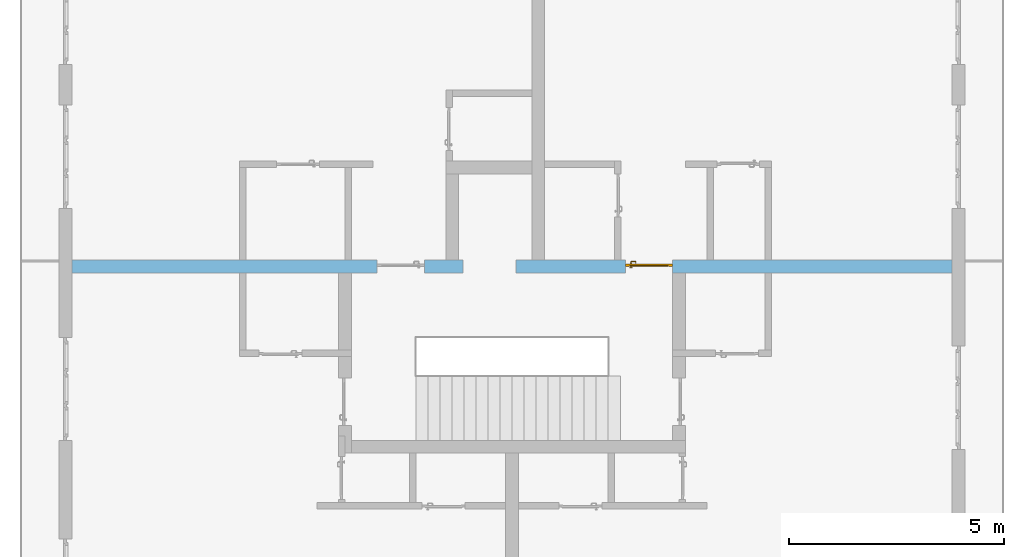
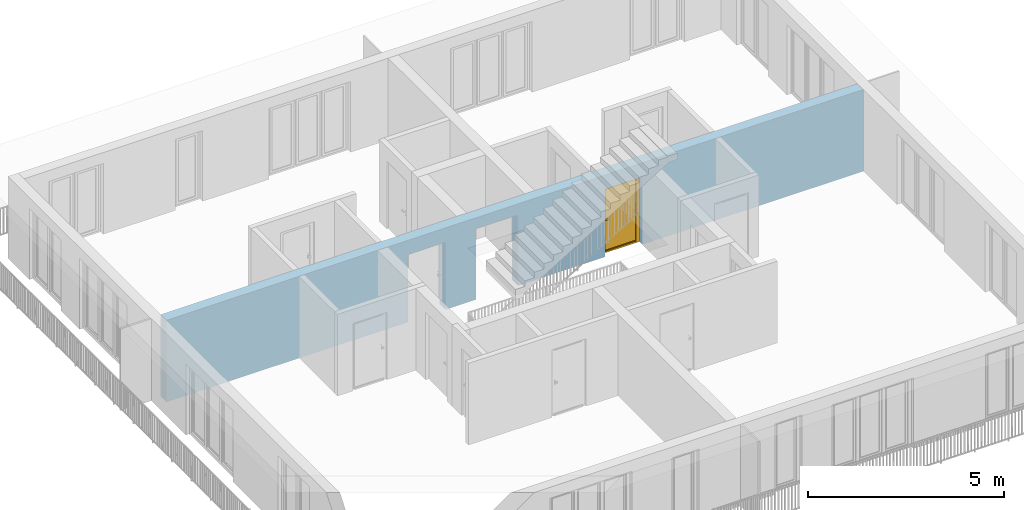
# One storey, part 14 of 48: 1 door, 3 openings, plus 1 element that does not belong to this part.
"""IFC4 building model written with IfcOpenShell, lengths in metres."""

from ifc_helpers import new_model, entity, si_unit, converted_unit, derived_unit, direction, frame, origin_with_axes, place, context, subcontext, project, spatial, polygons, source, transform, mapped, material, type_object, element, fill, save


model = new_model("IFC4")

# Units and contexts
model_context = context("Model", 3, precision=1e-05, world=origin_with_axes(), true_north=direction((0.0, 1.0)))
body_context = subcontext(model_context, "Body", "Model", "MODEL_VIEW")
ifc_project = project(units=[si_unit("LENGTHUNIT", "METRE"), si_unit("AREAUNIT", "SQUARE_METRE"), si_unit("VOLUMEUNIT", "CUBIC_METRE"), converted_unit("PLANEANGLEUNIT", "DEGREE", entity("IfcPlaneAngleMeasure", 0.0174532925199), si_unit("PLANEANGLEUNIT", "RADIAN"), dimensions=[0, 0, 0, 0, 0, 0, 0]), converted_unit("TIMEUNIT", "Year", entity("IfcTimeMeasure", 31556926.0), si_unit("TIMEUNIT", "SECOND"), dimensions=[0, 0, 1, 0, 0, 0, 0]), si_unit("MASSUNIT", "GRAM", prefix="KILO"), si_unit("THERMODYNAMICTEMPERATUREUNIT", "DEGREE_CELSIUS"), si_unit("LUMINOUSINTENSITYUNIT", "LUMEN"), si_unit("ENERGYUNIT", "JOULE", prefix="MEGA"), derived_unit("THERMALCONDUCTANCEUNIT", [(si_unit("POWERUNIT", "WATT"), 1), (si_unit("LENGTHUNIT", "METRE"), -1), (si_unit("THERMODYNAMICTEMPERATUREUNIT", "KELVIN"), -1)]), derived_unit("SPECIFICHEATCAPACITYUNIT", [(si_unit("ENERGYUNIT", "JOULE"), 1), (si_unit("MASSUNIT", "GRAM", prefix="KILO"), -1), (si_unit("THERMODYNAMICTEMPERATUREUNIT", "KELVIN"), -1)]), derived_unit("MASSDENSITYUNIT", [(si_unit("MASSUNIT", "GRAM", prefix="KILO"), 1), (si_unit("VOLUMEUNIT", "CUBIC_METRE"), -1)])], contexts=[model_context])

# Site, building, storey
site_placement = place(None, origin_with_axes())
site = spatial("IfcSite", under=ifc_project, at=site_placement, CompositionType="ELEMENT")
building_placement = place(site_placement, origin_with_axes())
building = spatial("IfcBuilding", under=site, at=building_placement, CompositionType="ELEMENT")
storey_placement = place(building_placement, frame((0.0, 0.0, 3.4), z_axis=(0.0, 0.0, 1.0), x_axis=(1.0, 0.0, 0.0)))
storey = spatial("IfcBuildingStorey", under=building, at=storey_placement, Name="1. Geschoss", CompositionType="ELEMENT", Elevation=3.4)

# Wall, openings, door
ifc_material = material()
wall_type = type_object("IfcWallType", Name="300", PredefinedType="NOTDEFINED")
wall_placement = place(storey_placement, frame((-11.7421993804, 1.37118776896, 0.0), z_axis=(0.0, 0.0, 1.0), x_axis=(1.0, 0.0, 0.0)))
wall = element("IfcWall", 1, at=wall_placement, inside=storey, type_object=wall_type, material=ifc_material, Name="Wand-001", PredefinedType="NOTDEFINED", context=body_context, shape_type="Tessellation", body=[
    polygons([(9.4, 0.3, 2.2), (9.4, 0.3, 0.0), (8.5, 0.3, 0.0), (8.5, 0.3, 2.1), (7.4, 0.3, 2.1), (7.4, 0.3, 0.0), (0.3, 0.3, 0.0), (0.3, 0.3, 2.54), (20.78, 0.3, 2.54), (20.78, 0.3, 0.0), (14.28, 0.3, 0.0), (14.28, 0.3, 2.1), (13.18, 0.3, 2.1), (13.18, 0.3, 0.0), (10.63, 0.3, 0.0), (10.63, 0.3, 2.2), (9.4, 0.0, 2.2), (9.4, 0.0, 0.0), (8.5, 0.0, 0.0), (8.5, 0.0, 2.1), (7.4, 0.0, 2.1), (7.4, 0.0, 0.0), (0.3, 0.0, 0.0), (0.3, 0.0, 2.54), (20.78, 0.0, 2.54), (20.78, 0.0, 0.0), (14.28, 0.0, 0.0), (14.28, 0.0, 2.1), (13.18, 0.0, 2.1), (13.18, 0.0, 0.0), (10.63, 0.0, 0.0), (10.63, 0.0, 2.2)], [[[1, 2, 3, 4, 5, 6, 7, 8, 9, 10, 11, 12, 13, 14, 15, 16]], [[2, 1, 17, 18]], [[2, 18, 19, 3]], [[20, 4, 3, 19]], [[21, 5, 4, 20]], [[22, 6, 5, 21]], [[7, 6, 22, 23]], [[24, 8, 7, 23]], [[25, 9, 8, 24]], [[9, 25, 26, 10]], [[10, 26, 27, 11]], [[11, 27, 28, 12]], [[12, 28, 29, 13]], [[13, 29, 30, 14]], [[31, 15, 14, 30]], [[16, 15, 31, 32]], [[1, 16, 32, 17]], [[32, 31, 30, 29, 28, 27, 26, 25, 24, 23, 22, 21, 20, 19, 18, 17]]], closed=True),
])
opening_1_placement = place(wall_placement, frame((7.95, 0.0, 0.0), z_axis=(0.0, 0.0, 1.0), x_axis=(1.0, 0.0, 0.0)))
element("IfcOpeningElement", 2, at=opening_1_placement, cuts=wall, context=body_context, identifier="Reference", shape_type="Tessellation", body=[
    polygons([(0.55, 0.15, 0.0), (0.55, 0.15, 2.1), (0.55, -0.001, 2.1), (0.55, -0.001, 0.0), (0.55, 0.301, 0.0), (0.55, 0.301, 2.1), (-0.55, 0.15, 2.1), (-0.55, -0.001, 2.1), (-0.55, 0.301, 2.1), (-0.55, -0.001, 0.0), (-0.55, 0.15, 0.0), (-0.55, 0.301, 0.0)], [[[1, 2, 3, 4]], [[2, 1, 5, 6]], [[7, 8, 3, 2, 6, 9]], [[8, 10, 4, 3]], [[1, 4, 10, 11, 12, 5]], [[6, 5, 12, 9]], [[7, 11, 10, 8]], [[11, 7, 9, 12]]], closed=True),
])
opening_2_placement = place(wall_placement, frame((13.73, 0.0, 0.0), z_axis=(0.0, 0.0, 1.0), x_axis=(1.0, 0.0, 0.0)))
opening_2 = element("IfcOpeningElement", 3, at=opening_2_placement, cuts=wall, context=body_context, identifier="Reference", shape_type="Tessellation", body=[
    polygons([(0.55, 0.15, 0.0), (0.55, 0.15, 2.1), (0.55, -0.001, 2.1), (0.55, -0.001, 0.0), (0.55, 0.301, 0.0), (0.55, 0.301, 2.1), (-0.55, 0.15, 2.1), (-0.55, -0.001, 2.1), (-0.55, 0.301, 2.1), (-0.55, -0.001, 0.0), (-0.55, 0.15, 0.0), (-0.55, 0.301, 0.0)], [[[1, 2, 3, 4]], [[2, 1, 5, 6]], [[7, 8, 3, 2, 6, 9]], [[8, 10, 4, 3]], [[1, 4, 10, 11, 12, 5]], [[6, 5, 12, 9]], [[7, 11, 10, 8]], [[11, 7, 9, 12]]], closed=True),
])
opening_3_placement = place(wall_placement, frame((10.015, 0.0, 0.0), z_axis=(0.0, 0.0, 1.0), x_axis=(1.0, 0.0, 0.0)))
element("IfcOpeningElement", 4, at=opening_3_placement, cuts=wall, context=body_context, identifier="Reference", shape_type="Tessellation", body=[
    polygons([(-0.615, -0.001, 2.2), (-0.615, -0.001, 0.0), (0.615, -0.001, 0.0), (0.615, -0.001, 2.2), (-0.615, 0.301, 2.2), (-0.615, 0.301, 0.0), (0.615, 0.301, 0.0), (0.615, 0.301, 2.2)], [[[1, 2, 3, 4]], [[5, 6, 2, 1]], [[6, 7, 3, 2]], [[7, 8, 4, 3]], [[8, 5, 1, 4]], [[7, 6, 5, 8]]], closed=True),
])
door_type = type_object("IfcDoorType", Name="Eingang 01 1-Fl 26", OperationType="SINGLE_SWING_RIGHT", PredefinedType="DOOR")
shared_shape = source(origin_with_axes(), body_context, "Body", "Tessellation", [
    polygons([(0.55, -0.05, 0.0), (0.55, -0.03, 0.0), (0.55, -0.03, 2.1), (0.55, -0.05, 2.1), (0.45, -0.05, 0.0), (0.45, -0.03, 0.0), (0.45, -0.03, 2.0), (0.1301, -0.03, 2.0), (0.0001, -0.03, 2.0), (-0.45, -0.03, 2.0), (-0.45, -0.03, 0.0), (-0.55, -0.03, 0.0), (-0.55, -0.03, 2.1), (-0.55, -0.05, 2.1), (-0.55, -0.05, 0.0), (-0.45, -0.05, 0.0), (-0.45, -0.05, 2.0), (0.0001, -0.05, 2.0), (0.1301, -0.05, 2.0), (0.45, -0.05, 2.0)], [[[1, 2, 3, 4]], [[5, 6, 2, 1]], [[2, 6, 7, 8, 9, 10, 11, 12, 13, 3]], [[4, 3, 13, 14]], [[1, 4, 14, 15, 16, 17, 18, 19, 20, 5]], [[20, 7, 6, 5]], [[19, 8, 7, 20]], [[18, 9, 8, 19]], [[17, 10, 9, 18]], [[16, 11, 10, 17]], [[15, 12, 11, 16]], [[14, 13, 12, 15]]], closed=True),
    polygons([(0.55, -0.03, 0.0), (0.55, 0.0, 0.0), (0.55, 0.0, 2.1), (0.55, -0.03, 2.1), (0.48, -0.03, 0.0), (0.48, 0.0, 0.0), (0.48, 0.0, 2.03), (0.1001, 0.0, 2.03), (0.0301, 0.0, 2.03), (-0.48, 0.0, 2.03), (-0.48, 0.0, 0.0), (-0.55, 0.0, 0.0), (-0.55, 0.0, 2.1), (-0.55, -0.03, 2.1), (-0.55, -0.03, 0.0), (-0.48, -0.03, 0.0), (-0.48, -0.03, 2.03), (0.0301, -0.03, 2.03), (0.1001, -0.03, 2.03), (0.48, -0.03, 2.03)], [[[1, 2, 3, 4]], [[5, 6, 2, 1]], [[2, 6, 7, 8, 9, 10, 11, 12, 13, 3]], [[4, 3, 13, 14]], [[1, 4, 14, 15, 16, 17, 18, 19, 20, 5]], [[20, 7, 6, 5]], [[19, 8, 7, 20]], [[18, 9, 8, 19]], [[17, 10, 9, 18]], [[16, 11, 10, 17]], [[15, 12, 11, 16]], [[14, 13, 12, 15]]], closed=True),
    polygons([(0.48, 0.01, 0.0), (-0.48, 0.01, 0.0), (-0.48, 0.01, 2.03), (0.48, 0.01, 2.03), (0.48, -0.03, 0.0), (-0.48, -0.03, 0.0), (-0.48, -0.03, 2.03), (0.48, -0.03, 2.03)], [[[1, 2, 3, 4]], [[2, 1, 5, 6]], [[3, 2, 6, 7]], [[4, 3, 7, 8]], [[1, 4, 8, 5]], [[6, 5, 8, 7]]], closed=True),
    polygons([(0.445, -0.05, 0.0), (0.445, -0.05, 0.05), (-0.445, -0.05, 0.05), (-0.445, -0.05, 0.0), (0.445, -0.03, 0.0), (0.445, -0.03, 0.07), (0.445, -0.035, 0.07), (-0.445, -0.035, 0.07), (-0.445, -0.03, 0.07), (-0.445, -0.03, 0.0)], [[[1, 2, 3, 4]], [[1, 5, 6, 7, 2]], [[2, 7, 8, 3]], [[4, 3, 8, 9, 10]], [[5, 1, 4, 10]], [[6, 5, 10, 9]], [[7, 6, 9, 8]]], closed=True),
    polygons([(-0.4335, 0.02, 1.0733826859), (-0.4335, 0.0199, 1.0733826859), (-0.42, 0.0199, 1.077), (-0.42, 0.02, 1.077), (-0.443382685902, 0.02, 1.0635), (-0.443382685902, 0.0199, 1.0635), (-0.4335, 0.0101, 1.0733826859), (-0.42, 0.0101, 1.077), (-0.4065, 0.0199, 1.0733826859), (-0.4065, 0.02, 1.0733826859), (-0.396617314098, 0.02, 1.0635), (-0.393, 0.02, 1.05), (-0.396617314098, 0.02, 1.0365), (-0.4065, 0.02, 1.0266173141), (-0.42, 0.02, 1.023), (-0.4335, 0.02, 1.0266173141), (-0.443382685902, 0.02, 1.0365), (-0.447, 0.02, 1.05), (-0.447, 0.0199, 1.05), (-0.443382685902, 0.0101, 1.0635), (-0.4335, 0.01, 1.0733826859), (-0.42, 0.01, 1.077), (-0.4065, 0.0101, 1.0733826859), (-0.396617314098, 0.0199, 1.0635), (-0.393, 0.0199, 1.05), (-0.396617314098, 0.0199, 1.0365), (-0.4065, 0.0199, 1.0266173141), (-0.42, 0.0199, 1.023), (-0.4335, 0.0199, 1.0266173141), (-0.443382685902, 0.0199, 1.0365), (-0.447, 0.0101, 1.05), (-0.443382685902, 0.01, 1.0635), (-0.447, 0.01, 1.05), (-0.443382685902, 0.01, 1.0365), (-0.4335, 0.01, 1.0266173141), (-0.42, 0.01, 1.023), (-0.4065, 0.01, 1.0266173141), (-0.396617314098, 0.01, 1.0365), (-0.393, 0.01, 1.05), (-0.396617314098, 0.01, 1.0635), (-0.4065, 0.01, 1.0733826859), (-0.396617314098, 0.0101, 1.0635), (-0.393, 0.0101, 1.05), (-0.396617314098, 0.0101, 1.0365), (-0.4065, 0.0101, 1.0266173141), (-0.42, 0.0101, 1.023), (-0.4335, 0.0101, 1.0266173141), (-0.443382685902, 0.0101, 1.0365)], [[[1, 2, 3, 4]], [[5, 6, 2, 1]], [[2, 7, 8, 3]], [[4, 3, 9, 10]], [[4, 10, 11, 12, 13, 14, 15, 16, 17, 18, 5, 1]], [[18, 19, 6, 5]], [[6, 20, 7, 2]], [[7, 21, 22, 8]], [[3, 8, 23, 9]], [[10, 9, 24, 11]], [[11, 24, 25, 12]], [[12, 25, 26, 13]], [[13, 26, 27, 14]], [[14, 27, 28, 15]], [[15, 28, 29, 16]], [[16, 29, 30, 17]], [[17, 30, 19, 18]], [[19, 31, 20, 6]], [[20, 32, 21, 7]], [[22, 21, 32, 33, 34, 35, 36, 37, 38, 39, 40, 41]], [[8, 22, 41, 23]], [[9, 23, 42, 24]], [[24, 42, 43, 25]], [[25, 43, 44, 26]], [[26, 44, 45, 27]], [[27, 45, 46, 28]], [[28, 46, 47, 29]], [[29, 47, 48, 30]], [[30, 48, 31, 19]], [[31, 33, 32, 20]], [[48, 34, 33, 31]], [[47, 35, 34, 48]], [[46, 36, 35, 47]], [[45, 37, 36, 46]], [[44, 38, 37, 45]], [[43, 39, 38, 44]], [[42, 40, 39, 43]], [[23, 41, 40, 42]]], closed=True),
    polygons([(-0.412532169224, 0.019, 0.959692280177), (-0.415, 0.019, 0.9544), (-0.415, 0.019, 0.952886751346), (-0.397569942042, 0.019, 0.96295), (-0.40705, 0.019, 0.972430057958), (-0.413279754556, 0.019, 0.961639806549), (-0.412532169224, 0.02, 0.959692280177), (-0.415, 0.02, 0.9544), (-0.415, 0.02, 0.952886751346), (-0.415, 0.02, 0.95), (-0.415, 0.02, 0.947113248654), (-0.415, 0.02, 0.941339745962), (-0.415, 0.02, 0.9375), (-0.415, 0.019, 0.9375), (-0.415, 0.019, 0.941339745962), (-0.415, 0.019, 0.947113248654), (-0.415, 0.019, 0.95), (-0.3941, 0.019, 0.95), (-0.397483339502, 0.019, 0.963), (-0.407, 0.019, 0.972516660498), (-0.414624817685, 0.019, 0.965143815798), (-0.42, 0.019, 0.9759), (-0.42, 0.019, 0.967425445323), (-0.414624817685, 0.02, 0.965143815798), (-0.413279754556, 0.02, 0.961639806549), (-0.40655, 0.02, 0.973296083362), (-0.396703916638, 0.02, 0.96345), (-0.3931, 0.02, 0.95), (-0.396703916638, 0.02, 0.93655), (-0.40655, 0.02, 0.926703916638), (-0.42, 0.02, 0.9231), (-0.42, 0.02, 0.9325), (-0.416464466094, 0.02, 0.933964466094), (-0.416464466094, 0.019, 0.933964466094), (-0.40705, 0.019, 0.927569942042), (-0.42, 0.019, 0.9325), (-0.42, 0.019, 0.9241), (-0.397569942042, 0.019, 0.93705), (-0.394, 0.019, 0.95), (-0.397483339502, 0.0189, 0.963), (-0.407, 0.0189, 0.972516660498), (-0.42, 0.019, 0.976), (-0.425375182315, 0.019, 0.965143815798), (-0.43295, 0.019, 0.972430057958), (-0.426720245444, 0.019, 0.961639806549), (-0.42, 0.02, 0.967425445323), (-0.42, 0.02, 0.9769), (-0.396617314098, 0.02, 0.9635), (-0.4065, 0.02, 0.973382685902), (-0.393, 0.02, 0.95), (-0.396617314098, 0.02, 0.9365), (-0.4065, 0.02, 0.926617314098), (-0.43345, 0.02, 0.926703916638), (-0.425, 0.02, 0.941339745962), (-0.425, 0.02, 0.9375), (-0.423535533906, 0.02, 0.933964466094), (-0.42, 0.02, 0.923), (-0.423535533906, 0.019, 0.933964466094), (-0.425, 0.019, 0.9375), (-0.425, 0.019, 0.941339745962), (-0.43295, 0.019, 0.927569942042), (-0.42, 0.019, 0.924), (-0.407, 0.019, 0.927483339502), (-0.397483339502, 0.019, 0.937), (-0.394, 0.0189, 0.95), (-0.397483339502, 0.0101, 0.963), (-0.407, 0.0101, 0.972516660498), (-0.42, 0.0189, 0.976), (-0.433, 0.019, 0.972516660498), (-0.425375182315, 0.02, 0.965143815798), (-0.427467830776, 0.019, 0.959692280177), (-0.442430057958, 0.019, 0.96295), (-0.425, 0.019, 0.952886751346), (-0.425, 0.019, 0.9544), (-0.427467830776, 0.02, 0.959692280177), (-0.426720245444, 0.02, 0.961639806549), (-0.43345, 0.02, 0.973296083362), (-0.42, 0.02, 0.977), (-0.396617314098, 0.0199, 0.9635), (-0.4065, 0.0199, 0.973382685902), (-0.393, 0.0199, 0.95), (-0.396617314098, 0.0199, 0.9365), (-0.4065, 0.0199, 0.926617314098), (-0.443296083362, 0.02, 0.93655), (-0.425, 0.02, 0.947113248654), (-0.425, 0.02, 0.9544), (-0.425, 0.019, 0.95), (-0.425, 0.019, 0.947113248654), (-0.425, 0.02, 0.95), (-0.425, 0.02, 0.952886751346), (-0.4335, 0.02, 0.926617314098), (-0.42, 0.0199, 0.923), (-0.442430057958, 0.019, 0.93705), (-0.433, 0.019, 0.927483339502), (-0.42, 0.0189, 0.924), (-0.407, 0.0189, 0.927483339502), (-0.397483339502, 0.0189, 0.937), (-0.394, 0.0101, 0.95), (-0.397483339502, 0.01, 0.963), (-0.407, 0.01, 0.972516660498), (-0.42, 0.0101, 0.976), (-0.433, 0.0189, 0.972516660498), (-0.442516660498, 0.019, 0.963), (-0.4459, 0.019, 0.95), (-0.443296083362, 0.02, 0.96345), (-0.4335, 0.02, 0.973382685902), (-0.42, 0.0199, 0.977), (-0.396617314098, 0.0101, 0.9635), (-0.4065, 0.0101, 0.973382685902), (-0.393, 0.0101, 0.95), (-0.396617314098, 0.0101, 0.9365), (-0.4065, 0.0101, 0.926617314098), (-0.443382685902, 0.02, 0.9365), (-0.4469, 0.02, 0.95), (-0.4335, 0.0199, 0.926617314098), (-0.42, 0.0101, 0.923), (-0.442516660498, 0.019, 0.937), (-0.433, 0.0189, 0.927483339502), (-0.42, 0.0101, 0.924), (-0.407, 0.0101, 0.927483339502), (-0.397483339502, 0.0101, 0.937), (-0.394, 0.01, 0.95), (-0.397396736961, 0.01, 0.96305), (-0.40695, 0.01, 0.972603263039), (-0.42, 0.01, 0.976), (-0.433, 0.0101, 0.972516660498), (-0.442516660498, 0.0189, 0.963), (-0.446, 0.019, 0.95), (-0.443382685902, 0.02, 0.9635), (-0.4335, 0.0199, 0.973382685902), (-0.42, 0.0101, 0.977), (-0.396617314098, 0.01, 0.9635), (-0.4065, 0.01, 0.973382685902), (-0.393, 0.01, 0.95), (-0.396617314098, 0.01, 0.9365), (-0.4065, 0.01, 0.926617314098), (-0.447, 0.02, 0.95), (-0.443382685902, 0.0199, 0.9365), (-0.4335, 0.0101, 0.926617314098), (-0.42, 0.01, 0.923), (-0.442516660498, 0.0189, 0.937), (-0.433, 0.0101, 0.927483339502), (-0.42, 0.01, 0.924), (-0.407, 0.01, 0.927483339502), (-0.397483339502, 0.01, 0.937), (-0.3939, 0.01, 0.95), (-0.396703916638, 0.01, 0.96345), (-0.40655, 0.01, 0.973296083362), (-0.42, 0.01, 0.9761), (-0.433, 0.01, 0.972516660498), (-0.442516660498, 0.0101, 0.963), (-0.446, 0.0189, 0.95), (-0.443382685902, 0.0199, 0.9635), (-0.4335, 0.0101, 0.973382685902), (-0.42, 0.01, 0.977), (-0.3931, 0.01, 0.95), (-0.396703916638, 0.01, 0.93655), (-0.40655, 0.01, 0.926703916638), (-0.447, 0.0199, 0.95), (-0.443382685902, 0.0101, 0.9365), (-0.4335, 0.01, 0.926617314098), (-0.42, 0.01, 0.9231), (-0.442516660498, 0.0101, 0.937), (-0.433, 0.01, 0.927483339502), (-0.42, 0.01, 0.9239), (-0.40695, 0.01, 0.927396736961), (-0.397396736961, 0.01, 0.93695), (-0.42, 0.01, 0.9769), (-0.43305, 0.01, 0.972603263039), (-0.442516660498, 0.01, 0.963), (-0.446, 0.0101, 0.95), (-0.443382685902, 0.0101, 0.9635), (-0.4335, 0.01, 0.973382685902), (-0.447, 0.0101, 0.95), (-0.443382685902, 0.01, 0.9365), (-0.43345, 0.01, 0.926703916638), (-0.442516660498, 0.01, 0.937), (-0.43305, 0.01, 0.927396736961), (-0.43345, 0.01, 0.973296083362), (-0.442603263039, 0.01, 0.96305), (-0.446, 0.01, 0.95), (-0.443382685902, 0.01, 0.9635), (-0.447, 0.01, 0.95), (-0.443296083362, 0.01, 0.93655), (-0.442603263039, 0.01, 0.93695), (-0.443296083362, 0.01, 0.96345), (-0.4461, 0.01, 0.95), (-0.4469, 0.01, 0.95)], [[[1, 2, 3, 4, 5, 6]], [[2, 1, 7, 8]], [[2, 8, 9, 10, 11, 12, 13, 14, 15, 16, 17, 3]], [[17, 18, 4, 3]], [[4, 19, 20, 5]], [[21, 6, 5, 22, 23]], [[1, 6, 21, 24, 25, 7]], [[7, 25, 26, 27, 9, 8]], [[9, 27, 28, 10]], [[10, 28, 29, 11]], [[11, 29, 30, 12]], [[31, 32, 33, 13, 12, 30]], [[14, 13, 33, 34]], [[35, 15, 14, 34, 36, 37]], [[15, 35, 38, 16]], [[16, 38, 18, 17]], [[18, 39, 19, 4]], [[19, 40, 41, 20]], [[5, 20, 42, 22]], [[43, 23, 22, 44, 45]], [[21, 23, 46, 24]], [[24, 46, 47, 26, 25]], [[48, 27, 26, 49]], [[50, 28, 27, 48]], [[51, 29, 28, 50]], [[52, 30, 29, 51]], [[53, 54, 55, 56, 32, 31]], [[34, 33, 32, 36]], [[57, 31, 30, 52]], [[37, 36, 58, 59, 60, 61]], [[37, 62, 63, 35]], [[35, 63, 64, 38]], [[38, 64, 39, 18]], [[39, 65, 40, 19]], [[40, 66, 67, 41]], [[20, 41, 68, 42]], [[22, 42, 69, 44]], [[23, 43, 70, 46]], [[71, 45, 44, 72, 73, 74]], [[43, 45, 71, 75, 76, 70]], [[70, 76, 77, 47, 46]], [[49, 26, 47, 78]], [[79, 48, 49, 80]], [[81, 50, 48, 79]], [[82, 51, 50, 81]], [[83, 52, 51, 82]], [[54, 53, 84, 85]], [[86, 74, 73, 87, 88, 60, 59, 55, 54, 85, 89, 90]], [[58, 56, 55, 59]], [[36, 32, 56, 58]], [[91, 53, 31, 57]], [[92, 57, 52, 83]], [[88, 93, 61, 60]], [[61, 94, 62, 37]], [[62, 95, 96, 63]], [[63, 96, 97, 64]], [[64, 97, 65, 39]], [[65, 98, 66, 40]], [[66, 99, 100, 67]], [[41, 67, 101, 68]], [[42, 68, 102, 69]], [[44, 69, 103, 72]], [[73, 72, 104, 87]], [[71, 74, 86, 75]], [[75, 86, 90, 105, 77, 76]], [[78, 47, 77, 106]], [[80, 49, 78, 107]], [[108, 79, 80, 109]], [[110, 81, 79, 108]], [[111, 82, 81, 110]], [[112, 83, 82, 111]], [[113, 84, 53, 91]], [[85, 84, 114, 89]], [[87, 104, 93, 88]], [[89, 114, 105, 90]], [[115, 91, 57, 92]], [[116, 92, 83, 112]], [[93, 117, 94, 61]], [[94, 118, 95, 62]], [[95, 119, 120, 96]], [[96, 120, 121, 97]], [[97, 121, 98, 65]], [[98, 122, 99, 66]], [[99, 123, 124, 100]], [[67, 100, 125, 101]], [[68, 101, 126, 102]], [[69, 102, 127, 103]], [[72, 103, 128, 104]], [[106, 77, 105, 129]], [[107, 78, 106, 130]], [[109, 80, 107, 131]], [[132, 108, 109, 133]], [[134, 110, 108, 132]], [[135, 111, 110, 134]], [[136, 112, 111, 135]], [[137, 114, 84, 113]], [[138, 113, 91, 115]], [[104, 128, 117, 93]], [[129, 105, 114, 137]], [[139, 115, 92, 116]], [[140, 116, 112, 136]], [[117, 141, 118, 94]], [[118, 142, 119, 95]], [[119, 143, 144, 120]], [[120, 144, 145, 121]], [[121, 145, 122, 98]], [[122, 146, 123, 99]], [[123, 147, 148, 124]], [[100, 124, 149, 125]], [[101, 125, 150, 126]], [[102, 126, 151, 127]], [[103, 127, 152, 128]], [[130, 106, 129, 153]], [[131, 107, 130, 154]], [[133, 109, 131, 155]], [[147, 132, 133, 148]], [[156, 134, 132, 147]], [[157, 135, 134, 156]], [[158, 136, 135, 157]], [[159, 137, 113, 138]], [[160, 138, 115, 139]], [[128, 152, 141, 117]], [[153, 129, 137, 159]], [[161, 139, 116, 140]], [[162, 140, 136, 158]], [[141, 163, 142, 118]], [[142, 164, 143, 119]], [[143, 165, 166, 144]], [[144, 166, 167, 145]], [[145, 167, 146, 122]], [[146, 156, 147, 123]], [[124, 148, 168, 149]], [[125, 149, 169, 150]], [[126, 150, 170, 151]], [[127, 151, 171, 152]], [[154, 130, 153, 172]], [[155, 131, 154, 173]], [[148, 133, 155, 168]], [[167, 157, 156, 146]], [[166, 158, 157, 167]], [[174, 159, 138, 160]], [[175, 160, 139, 161]], [[152, 171, 163, 141]], [[172, 153, 159, 174]], [[176, 161, 140, 162]], [[165, 162, 158, 166]], [[163, 177, 164, 142]], [[164, 178, 165, 143]], [[149, 168, 179, 169]], [[150, 169, 180, 170]], [[151, 170, 181, 171]], [[173, 154, 172, 182]], [[168, 155, 173, 179]], [[183, 174, 160, 175]], [[184, 175, 161, 176]], [[171, 181, 177, 163]], [[182, 172, 174, 183]], [[178, 176, 162, 165]], [[177, 185, 178, 164]], [[169, 179, 186, 180]], [[170, 180, 187, 181]], [[179, 173, 182, 186]], [[188, 183, 175, 184]], [[185, 184, 176, 178]], [[181, 187, 185, 177]], [[186, 182, 183, 188]], [[180, 186, 188, 187]], [[187, 188, 184, 185]]], closed=True),
    polygons([(-0.43, 0.02, 1.05), (-0.43, 0.0509849140336, 1.05), (-0.427071067812, 0.050696439392, 1.04292893219), (-0.427071067812, 0.02, 1.04292893219), (-0.427071067812, 0.02, 1.05707106781), (-0.427071067812, 0.050696439392, 1.05707106781), (-0.428277987014, 0.0596420579258, 1.05), (-0.425518993221, 0.0584992452783, 1.04292893219), (-0.42, 0.05, 1.04), (-0.42, 0.02, 1.04), (-0.42, 0.02, 1.06), (-0.42, 0.05, 1.06), (-0.425518993221, 0.0584992452783, 1.05707106781), (-0.422816199938, 0.0678161999379, 1.05), (-0.420704557509, 0.0657045575088, 1.04292893219), (-0.418858192988, 0.0557402514855, 1.04), (-0.412928932188, 0.049303560608, 1.04292893219), (-0.412928932188, 0.02, 1.04292893219), (-0.412928932188, 0.02, 1.05707106781), (-0.412928932188, 0.049303560608, 1.05707106781), (-0.418858192988, 0.0557402514855, 1.06), (-0.420704557509, 0.0657045575088, 1.05707106781), (-0.414642057926, 0.0732779870137, 1.05), (-0.413499245278, 0.0705189932208, 1.04292893219), (-0.415606601718, 0.0606066017178, 1.04), (-0.412197392755, 0.0529812576926, 1.04292893219), (-0.41, 0.0490150859664, 1.05), (-0.41, 0.02, 1.05), (-0.412197392755, 0.0529812576926, 1.05707106781), (-0.415606601718, 0.0606066017178, 1.06), (-0.413499245278, 0.0705189932208, 1.05707106781), (-0.405984914034, 0.075, 1.05), (-0.405696439392, 0.0720710678119, 1.04292893219), (-0.410740251485, 0.0638581929877, 1.04), (-0.410508645927, 0.0555086459268, 1.04292893219), (-0.409438398962, 0.0518384450452, 1.05), (-0.410508645927, 0.0555086459268, 1.05707106781), (-0.410740251485, 0.0638581929877, 1.06), (-0.405696439392, 0.0720710678119, 1.05707106781), (-0.324015085966, 0.075, 1.05), (-0.324303560608, 0.0720710678119, 1.04292893219), (-0.405, 0.065, 1.04), (-0.407981257693, 0.0571973927545, 1.04292893219), (-0.408397003498, 0.0533970034977, 1.05), (-0.407981257693, 0.0571973927545, 1.05707106781), (-0.405, 0.065, 1.06), (-0.324303560608, 0.0720710678119, 1.05707106781), (-0.315357942074, 0.0732779870137, 1.05), (-0.316500754722, 0.0705189932208, 1.04292893219), (-0.325, 0.065, 1.04), (-0.404303560608, 0.0579289321881, 1.04292893219), (-0.406838445045, 0.0544383989617, 1.05), (-0.404303560608, 0.0579289321881, 1.05707106781), (-0.325, 0.065, 1.06), (-0.316500754722, 0.0705189932208, 1.05707106781), (-0.307183800062, 0.0678161999379, 1.05), (-0.309295442491, 0.0657045575088, 1.04292893219), (-0.319259748515, 0.0638581929877, 1.04), (-0.325696439392, 0.0579289321881, 1.04292893219), (-0.404015085966, 0.055, 1.05), (-0.325696439392, 0.0579289321881, 1.05707106781), (-0.319259748515, 0.0638581929877, 1.06), (-0.309295442491, 0.0657045575088, 1.05707106781), (-0.301722012986, 0.0596420579258, 1.05), (-0.304481006779, 0.0584992452783, 1.04292893219), (-0.314393398282, 0.0606066017178, 1.04), (-0.322018742307, 0.0571973927545, 1.04292893219), (-0.325984914034, 0.055, 1.05), (-0.322018742307, 0.0571973927545, 1.05707106781), (-0.314393398282, 0.0606066017178, 1.06), (-0.304481006779, 0.0584992452783, 1.05707106781), (-0.3, 0.0509849140336, 1.05), (-0.302928932188, 0.050696439392, 1.04292893219), (-0.311141807012, 0.0557402514855, 1.04), (-0.319491354073, 0.0555086459268, 1.04292893219), (-0.323161554955, 0.0544383989617, 1.05), (-0.319491354073, 0.0555086459268, 1.05707106781), (-0.311141807012, 0.0557402514855, 1.06), (-0.302928932188, 0.050696439392, 1.05707106781), (-0.3, 0.02, 1.05), (-0.302928932188, 0.02, 1.04292893219), (-0.31, 0.05, 1.04), (-0.317802607245, 0.0529812576926, 1.04292893219), (-0.321602996502, 0.0533970034977, 1.05), (-0.317802607245, 0.0529812576926, 1.05707106781), (-0.31, 0.05, 1.06), (-0.302928932188, 0.02, 1.05707106781), (-0.31, 0.02, 1.06), (-0.317071067812, 0.02, 1.05707106781), (-0.32, 0.02, 1.05), (-0.317071067812, 0.02, 1.04292893219), (-0.31, 0.02, 1.04), (-0.317071067812, 0.049303560608, 1.04292893219), (-0.320561601038, 0.0518384450452, 1.05), (-0.317071067812, 0.049303560608, 1.05707106781), (-0.32, 0.0490150859664, 1.05)], [[[1, 2, 3, 4]], [[5, 6, 2, 1]], [[2, 7, 8, 3]], [[4, 3, 9, 10]], [[11, 12, 6, 5]], [[6, 13, 7, 2]], [[7, 14, 15, 8]], [[3, 8, 16, 9]], [[10, 9, 17, 18]], [[19, 20, 12, 11]], [[12, 21, 13, 6]], [[13, 22, 14, 7]], [[14, 23, 24, 15]], [[8, 15, 25, 16]], [[9, 16, 26, 17]], [[18, 17, 27, 28]], [[28, 27, 20, 19]], [[20, 29, 21, 12]], [[21, 30, 22, 13]], [[22, 31, 23, 14]], [[23, 32, 33, 24]], [[15, 24, 34, 25]], [[16, 25, 35, 26]], [[17, 26, 36, 27]], [[27, 36, 29, 20]], [[29, 37, 30, 21]], [[30, 38, 31, 22]], [[31, 39, 32, 23]], [[32, 40, 41, 33]], [[24, 33, 42, 34]], [[25, 34, 43, 35]], [[26, 35, 44, 36]], [[36, 44, 37, 29]], [[37, 45, 38, 30]], [[38, 46, 39, 31]], [[39, 47, 40, 32]], [[40, 48, 49, 41]], [[33, 41, 50, 42]], [[34, 42, 51, 43]], [[35, 43, 52, 44]], [[44, 52, 45, 37]], [[45, 53, 46, 38]], [[46, 54, 47, 39]], [[47, 55, 48, 40]], [[48, 56, 57, 49]], [[41, 49, 58, 50]], [[42, 50, 59, 51]], [[43, 51, 60, 52]], [[52, 60, 53, 45]], [[53, 61, 54, 46]], [[54, 62, 55, 47]], [[55, 63, 56, 48]], [[56, 64, 65, 57]], [[49, 57, 66, 58]], [[50, 58, 67, 59]], [[51, 59, 68, 60]], [[60, 68, 61, 53]], [[61, 69, 62, 54]], [[62, 70, 63, 55]], [[63, 71, 64, 56]], [[64, 72, 73, 65]], [[57, 65, 74, 66]], [[58, 66, 75, 67]], [[59, 67, 76, 68]], [[68, 76, 69, 61]], [[69, 77, 70, 62]], [[70, 78, 71, 63]], [[71, 79, 72, 64]], [[72, 80, 81, 73]], [[65, 73, 82, 74]], [[66, 74, 83, 75]], [[67, 75, 84, 76]], [[76, 84, 77, 69]], [[77, 85, 78, 70]], [[78, 86, 79, 71]], [[79, 87, 80, 72]], [[80, 87, 88, 89, 90, 91, 92, 81]], [[73, 81, 92, 82]], [[74, 82, 93, 83]], [[75, 83, 94, 84]], [[84, 94, 85, 77]], [[85, 95, 86, 78]], [[86, 88, 87, 79]], [[95, 89, 88, 86]], [[96, 90, 89, 95]], [[93, 91, 90, 96]], [[82, 92, 91, 93]], [[83, 93, 96, 94]], [[94, 96, 95, 85]]], closed=False),
    polygons([(-0.414696699141, -0.035, 1.04469669914), (-0.42, -0.035, 1.0425), (-0.425303300859, -0.035, 1.04469669914), (-0.4275, -0.035, 1.05), (-0.425303300859, -0.035, 1.05530330086), (-0.42, -0.035, 1.0575), (-0.414696699141, -0.035, 1.05530330086), (-0.4125, -0.035, 1.05), (-0.414696699141, -0.075, 1.04469669914), (-0.42, -0.075, 1.0425), (-0.425303300859, -0.075, 1.04469669914), (-0.4275, -0.075, 1.05), (-0.425303300859, -0.075, 1.05530330086), (-0.42, -0.075, 1.0575), (-0.414696699141, -0.075, 1.05530330086), (-0.4125, -0.075, 1.05)], [[[1, 2, 3, 4, 5, 6, 7, 8]], [[2, 1, 9, 10]], [[3, 2, 10, 11]], [[4, 3, 11, 12]], [[5, 4, 12, 13]], [[6, 5, 13, 14]], [[7, 6, 14, 15]], [[8, 7, 15, 16]], [[1, 8, 16, 9]], [[9, 16, 15, 14, 13, 12, 11, 10]]], closed=True),
    polygons([(-0.445, -0.03, 0.975), (-0.443096988313, -0.03, 0.965432914191), (-0.443096988313, -0.035, 0.965432914191), (-0.445, -0.035, 0.975), (-0.445, -0.03, 1.1), (-0.443096988313, -0.03, 1.10956708581), (-0.43767766953, -0.03, 1.11767766953), (-0.429567085809, -0.03, 1.12309698831), (-0.42, -0.03, 1.125), (-0.410432914191, -0.03, 1.12309698831), (-0.40232233047, -0.03, 1.11767766953), (-0.396903011687, -0.03, 1.10956708581), (-0.395, -0.03, 1.1), (-0.395, -0.03, 0.975), (-0.396903011687, -0.03, 0.965432914191), (-0.40232233047, -0.03, 0.95732233047), (-0.410432914191, -0.03, 0.951903011687), (-0.42, -0.03, 0.95), (-0.429567085809, -0.03, 0.951903011687), (-0.43767766953, -0.03, 0.95732233047), (-0.43767766953, -0.035, 0.95732233047), (-0.429567085809, -0.035, 0.951903011687), (-0.42, -0.035, 0.95), (-0.410432914191, -0.035, 0.951903011687), (-0.40232233047, -0.035, 0.95732233047), (-0.396903011687, -0.035, 0.965432914191), (-0.395, -0.035, 0.975), (-0.395, -0.035, 1.1), (-0.396903011687, -0.035, 1.10956708581), (-0.40232233047, -0.035, 1.11767766953), (-0.410432914191, -0.035, 1.12309698831), (-0.42, -0.035, 1.125), (-0.429567085809, -0.035, 1.12309698831), (-0.43767766953, -0.035, 1.11767766953), (-0.443096988313, -0.035, 1.10956708581), (-0.445, -0.035, 1.1)], [[[1, 2, 3, 4]], [[1, 5, 6, 7, 8, 9, 10, 11, 12, 13, 14, 15, 16, 17, 18, 19, 20, 2]], [[2, 20, 21, 3]], [[4, 3, 21, 22, 23, 24, 25, 26, 27, 28, 29, 30, 31, 32, 33, 34, 35, 36]], [[5, 1, 4, 36]], [[6, 5, 36, 35]], [[7, 6, 35, 34]], [[8, 7, 34, 33]], [[9, 8, 33, 32]], [[10, 9, 32, 31]], [[11, 10, 31, 30]], [[12, 11, 30, 29]], [[13, 12, 29, 28]], [[14, 13, 28, 27]], [[15, 14, 27, 26]], [[16, 15, 26, 25]], [[17, 16, 25, 24]], [[18, 17, 24, 23]], [[19, 18, 23, 22]], [[20, 19, 22, 21]]], closed=True),
    polygons([(-0.44, -0.075, 1.08), (-0.445, -0.075, 1.07866025404), (-0.445, -0.09, 1.07866025404), (-0.44, -0.09, 1.08), (-0.4, -0.075, 1.08), (-0.395, -0.075, 1.07866025404), (-0.391339745962, -0.075, 1.075), (-0.39, -0.075, 1.07), (-0.39, -0.075, 1.03), (-0.391339745962, -0.075, 1.025), (-0.395, -0.075, 1.02133974596), (-0.4, -0.075, 1.02), (-0.44, -0.075, 1.02), (-0.445, -0.075, 1.02133974596), (-0.448660254038, -0.075, 1.025), (-0.45, -0.075, 1.03), (-0.45, -0.075, 1.07), (-0.448660254038, -0.075, 1.075), (-0.448660254038, -0.09, 1.075), (-0.45, -0.09, 1.07), (-0.45, -0.09, 1.03), (-0.448660254038, -0.09, 1.025), (-0.445, -0.09, 1.02133974596), (-0.44, -0.09, 1.02), (-0.4, -0.09, 1.02), (-0.395, -0.09, 1.02133974596), (-0.391339745962, -0.09, 1.025), (-0.39, -0.09, 1.03), (-0.39, -0.09, 1.07), (-0.391339745962, -0.09, 1.075), (-0.395, -0.09, 1.07866025404), (-0.4, -0.09, 1.08)], [[[1, 2, 3, 4]], [[1, 5, 6, 7, 8, 9, 10, 11, 12, 13, 14, 15, 16, 17, 18, 2]], [[2, 18, 19, 3]], [[4, 3, 19, 20, 21, 22, 23, 24, 25, 26, 27, 28, 29, 30, 31, 32]], [[5, 1, 4, 32]], [[6, 5, 32, 31]], [[7, 6, 31, 30]], [[8, 7, 30, 29]], [[9, 8, 29, 28]], [[10, 9, 28, 27]], [[11, 10, 27, 26]], [[12, 11, 26, 25]], [[13, 12, 25, 24]], [[14, 13, 24, 23]], [[15, 14, 23, 22]], [[16, 15, 22, 21]], [[17, 16, 21, 20]], [[18, 17, 20, 19]]], closed=True),
])
door_placement = place(opening_2_placement, frame((-0.45, 0.0, 0.0), z_axis=(0.0, 0.0, 1.0), x_axis=(1.0, 0.0, 0.0)))
door = element("IfcDoor", 5, at=door_placement, inside=storey, type_object=door_type, OverallHeight=2.1, OverallWidth=1.1, PredefinedType="DOOR", context=body_context, shape_type="MappedRepresentation", body=[
    mapped(shared_shape, transform((0.45, 0.2, 0.0))),
])
fill(opening_2, door)

save(model, "model.ifc")
